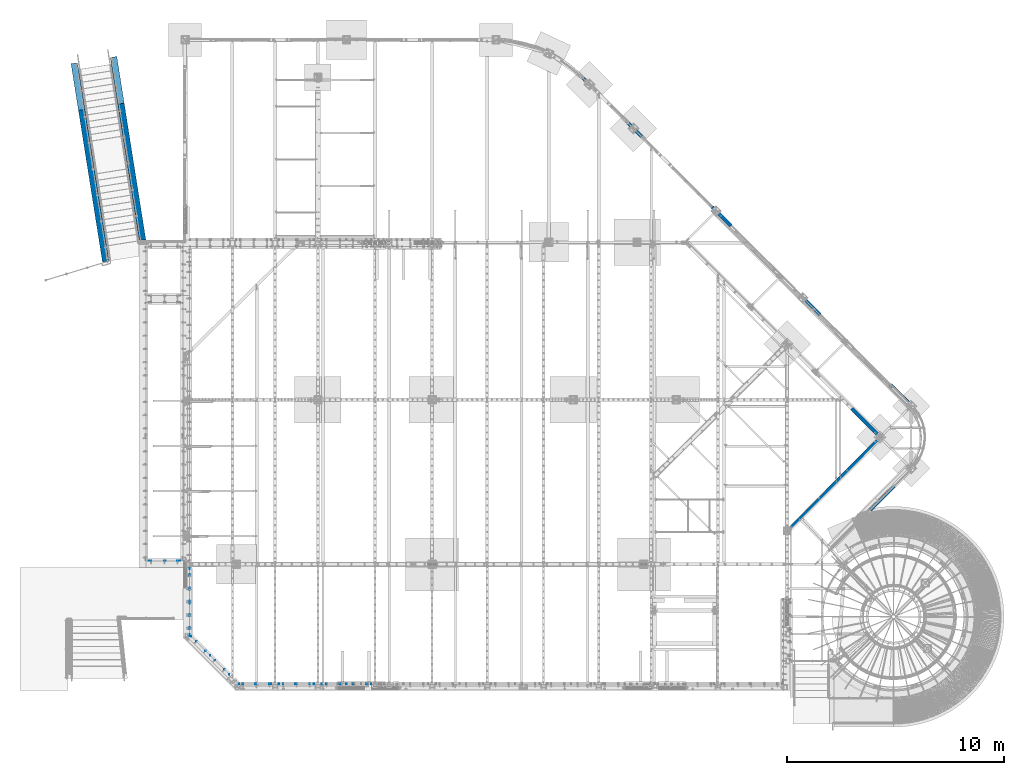
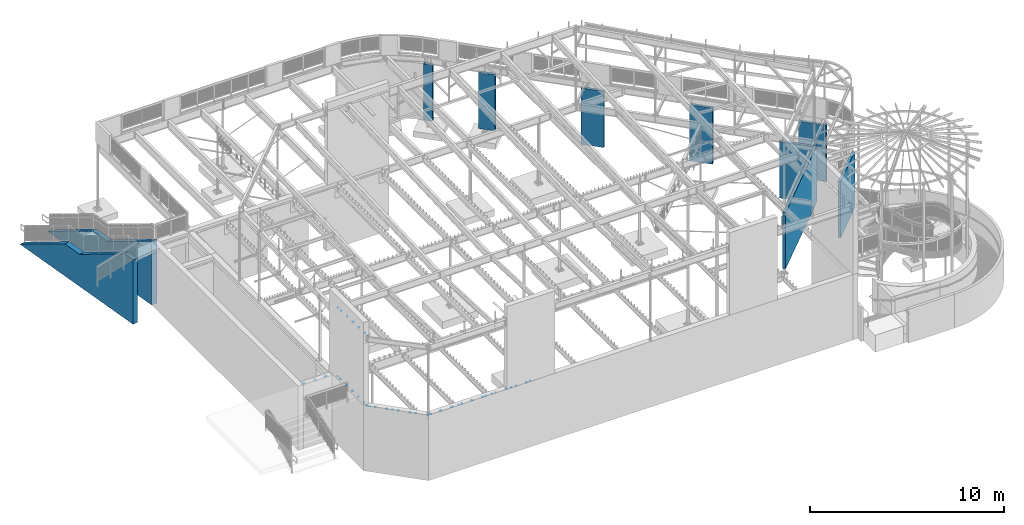
# One storey, part 1 of 975: 14 mechanical fasteners, 10 walls.
"""IFC2X3 building model written with IfcOpenShell, lengths in millimetres."""

import ifcopenshell
import ifcopenshell.guid

model = None  # the IFC model being written
_history = None  # IfcOwnerHistory: only IFC2X3 demands one
_inside = {}  # id of a spatial element -> (the spatial element, [elements in it])
_under = {}  # id of a project, library or spatial element -> (it, [spatial elements below it])
_declared = {}  # id of a project -> (the project, [libraries it declares])
_typed = {}  # id of a type object -> (the type object, [elements of that type])
_made_of = {}  # id of a material, layer set ... -> (it, [elements and type objects made of it])


def new_model(schema):
    """Start an empty IFC model of exactly this schema.

    Asked for "IFC4X3", IfcOpenShell would pick the latest addendum, in which some entities
    have other attributes; the version numbers below select the first issue.
    IFC2X3 requires an IfcOwnerHistory on every rooted entity: one is made here for all.
    """
    global model, _history
    if schema == "IFC4X3":
        model = ifcopenshell.file(schema_version=(4, 3, 0, 0))
    else:
        model = ifcopenshell.file(schema=schema)
    _inside.clear()
    _under.clear()
    _declared.clear()
    _typed.clear()
    _made_of.clear()
    _history = None
    if model.schema == "IFC2X3":
        org = make("IfcOrganization", Name="unknown")
        user = make(
            "IfcPersonAndOrganization",
            ThePerson=make("IfcPerson", FamilyName="unknown"),
            TheOrganization=org,
        )
        app = make(
            "IfcApplication",
            ApplicationDeveloper=org,
            Version="unknown",
            ApplicationFullName="unknown",
            ApplicationIdentifier="unknown",
        )
        _history = make(
            "IfcOwnerHistory",
            OwningUser=user,
            OwningApplication=app,
            ChangeAction="ADDED",
            CreationDate=0,
        )
    return model


def make(cls, **values):
    """One entity of the class cls with the attributes given. An attribute that is None is left unset."""
    return model.create_entity(
        cls, **{name: value for name, value in values.items() if value is not None}
    )


def rooted(cls, **values):
    """An entity with a GlobalId (a new one), such as an element, a storey or a relation."""
    return make(cls, GlobalId=ifcopenshell.guid.new(), OwnerHistory=_history, **values)


def si_unit(unit_type, name, prefix=None):
    """IfcSIUnit, for example si_unit("LENGTHUNIT", "METRE", prefix="MILLI")."""
    return make("IfcSIUnit", UnitType=unit_type, Prefix=prefix, Name=name)


def assignment(units):
    """IfcUnitAssignment: the units of a project."""
    return None if units is None else make("IfcUnitAssignment", Units=units)


def point(xyz):
    """IfcCartesianPoint."""
    return None if xyz is None else make("IfcCartesianPoint", Coordinates=xyz)


def direction(xyz):
    """IfcDirection."""
    return None if xyz is None else make("IfcDirection", DirectionRatios=xyz)


def frame(location, z_axis=None, x_axis=None):
    """IfcAxis2Placement3D, a coordinate frame: its origin and axes. An axis left out is left unset."""
    return make(
        "IfcAxis2Placement3D",
        Location=point(location),
        Axis=direction(z_axis),
        RefDirection=direction(x_axis),
    )


def origin_with_axes():
    """The frame at (0, 0, 0) with the z axis (0, 0, 1) and the x axis (1, 0, 0) written out."""
    return frame((0.0, 0.0, 0.0), z_axis=(0.0, 0.0, 1.0), x_axis=(1.0, 0.0, 0.0))


def place(relative_to, where):
    """IfcLocalPlacement: puts the frame where relative to a parent placement (None: the world)."""
    return make(
        "IfcLocalPlacement", PlacementRelTo=relative_to, RelativePlacement=where
    )


def context(
    kind, dimensions, precision=None, world=None, true_north=None, identifier=None
):
    """IfcGeometricRepresentationContext, for example the 3D "Model" context."""
    return make(
        "IfcGeometricRepresentationContext",
        ContextIdentifier=identifier,
        ContextType=kind,
        CoordinateSpaceDimension=dimensions,
        Precision=precision,
        WorldCoordinateSystem=world,
        TrueNorth=true_north,
    )


def subcontext(parent, identifier, kind, view, scale=None):
    """IfcGeometricRepresentationSubContext, for example "Body" below "Model"."""
    return make(
        "IfcGeometricRepresentationSubContext",
        ContextIdentifier=identifier,
        ContextType=kind,
        ParentContext=parent,
        TargetScale=scale,
        TargetView=view,
    )


def project(units=None, contexts=None):
    """IfcProject with its units and contexts."""
    return rooted(
        "IfcProject",
        Name="project",
        RepresentationContexts=contexts,
        UnitsInContext=assignment(units),
    )


def spatial(cls, under=None, at=None, **own):
    """A site, building, storey or space (cls), placed at a placement, below another one or the project."""
    s = rooted(cls, ObjectPlacement=at, **own)
    if under is not None:
        _under.setdefault(under.id(), (under, []))[1].append(s)
    return s


def faces_of(points, faces, orient=None, outer=None):
    """IfcFace entities. A face is a list of loops; a loop is a list of indices into points, from 0.

    orient and outer hold one flag for each loop. By default every Orientation is true, the
    first loop of a face is its IfcFaceOuterBound and the others are IfcFaceBound.
    """
    made = []
    for i, loops in enumerate(faces):
        bounds = []
        for j, loop in enumerate(loops):
            is_outer = j == 0 if outer is None else outer[i][j]
            bounds.append(
                make(
                    "IfcFaceOuterBound" if is_outer else "IfcFaceBound",
                    Bound=make("IfcPolyLoop", Polygon=[points[k] for k in loop]),
                    Orientation=True if orient is None else orient[i][j],
                )
            )
        made.append(make("IfcFace", Bounds=bounds))
    return made


def faceted_brep(points, faces, orient=None, outer=None, voids=None):
    """IfcFacetedBrep: a solid bounded by flat faces; with voids (closed shells), ...WithVoids."""
    shared = [point(p) for p in points]
    hull = make("IfcClosedShell", CfsFaces=faces_of(shared, faces, orient, outer))
    if voids is None:
        return make("IfcFacetedBrep", Outer=hull)
    return make(
        "IfcFacetedBrepWithVoids",
        Outer=hull,
        Voids=[
            make(cls, CfsFaces=faces_of(shared, fs, o, b)) for cls, fs, o, b in voids
        ],
    )


def shape(context_of_items, identifier, shape_type, items):
    """IfcShapeRepresentation: the items that make up one representation, for example the "Body"."""
    return make(
        "IfcShapeRepresentation",
        ContextOfItems=context_of_items,
        RepresentationIdentifier=identifier,
        RepresentationType=shape_type,
        Items=items,
    )


def source(mapping_origin, context_of_items, identifier, shape_type, items):
    """IfcRepresentationMap: a shape defined once, which mapped items show again and again."""
    return make(
        "IfcRepresentationMap",
        MappingOrigin=mapping_origin,
        MappedRepresentation=shape(context_of_items, identifier, shape_type, items),
    )


def transform(
    local_origin,
    x_axis=None,
    y_axis=None,
    z_axis=None,
    scale=None,
    scale2=None,
    scale3=None,
    uniform=True,
):
    """IfcCartesianTransformationOperator3D, or its non-uniform kind. x_axis, y_axis, z_axis: its Axis1, 2, 3."""
    if uniform:
        return make(
            "IfcCartesianTransformationOperator3D",
            Axis1=direction(x_axis),
            Axis2=direction(y_axis),
            LocalOrigin=point(local_origin),
            Scale=scale,
            Axis3=direction(z_axis),
        )
    return make(
        "IfcCartesianTransformationOperator3DnonUniform",
        Axis1=direction(x_axis),
        Axis2=direction(y_axis),
        LocalOrigin=point(local_origin),
        Scale=scale,
        Axis3=direction(z_axis),
        Scale2=scale2,
        Scale3=scale3,
    )


def mapped(mapping_source, mapping_target):
    """IfcMappedItem: shows the shape of a source again, moved by a transform."""
    return make(
        "IfcMappedItem", MappingSource=mapping_source, MappingTarget=mapping_target
    )


def material(Name=None, Category=None):
    """IfcMaterial."""
    return make("IfcMaterial", Name=Name, Category=Category)


def made_of(thing, what):
    """Note that an element or type object is made of a material, layer set ...; save() writes the relation."""
    if what is not None:
        _made_of.setdefault(what.id(), (what, []))[1].append(thing)
    return thing


def type_object(cls, material=None, **own):
    """A type object (cls), such as IfcWallType, which elements share."""
    return made_of(rooted(cls, **own), material)


def element(
    cls,
    number,
    at=None,
    inside=None,
    cuts=None,
    type_object=None,
    material=None,
    context=None,
    identifier="Body",
    shape_type=None,
    held_by="IfcProductDefinitionShape",
    body=None,
    shapes=None,
    **own,
):
    """One element of the class cls, such as IfcWall. Its Tag is "e" and its number.

    at: its placement. inside: the storey or other place that contains it. cuts: it is an
    opening in that element (IfcRelVoidsElement). A single representation is given by context,
    identifier, shape_type and body (its items); several are given by shapes. held_by: the class
    of the entity that holds the representations. save() writes the other relations.
    """
    e = rooted(cls, Tag="e%d" % number, ObjectPlacement=at, **own)
    if body is not None:
        shapes = [shape(context, identifier, shape_type, body)]
    if shapes is not None:
        e.Representation = make(held_by, Representations=shapes)
    if inside is not None:
        _inside.setdefault(inside.id(), (inside, []))[1].append(e)
    if cuts is not None:
        rooted(
            "IfcRelVoidsElement", RelatingBuildingElement=cuts, RelatedOpeningElement=e
        )
    if type_object is not None:
        _typed.setdefault(type_object.id(), (type_object, []))[1].append(e)
    return made_of(e, material)


def aggregate(whole, parts):
    """IfcRelAggregates: a whole, such as a stair, and the parts it consists of."""
    return rooted("IfcRelAggregates", RelatingObject=whole, RelatedObjects=parts)


def save(model, path):
    """Write the relations noted so far, then the file.

    IfcRelAggregates (storeys below a building ...), IfcRelContainedInSpatialStructure (elements
    in a storey), IfcRelDefinesByType, IfcRelAssociatesMaterial and IfcRelDeclares: one each for
    every whole, place, type object, material and project.
    """
    for whole, parts in _under.values():
        aggregate(whole, parts)
    for where, things in _inside.values():
        rooted(
            "IfcRelContainedInSpatialStructure",
            RelatedElements=things,
            RelatingStructure=where,
        )
    for kind, things in _typed.values():
        rooted("IfcRelDefinesByType", RelatedObjects=things, RelatingType=kind)
    for what, things in _made_of.values():
        rooted("IfcRelAssociatesMaterial", RelatedObjects=things, RelatingMaterial=what)
    for by, libraries in _declared.values():
        rooted("IfcRelDeclares", RelatingContext=by, RelatedDefinitions=libraries)
    model.write(path)


model = new_model("IFC2X3")

# Units and contexts
model_context = context("Model", 3, precision=1e-05, world=origin_with_axes())
body_context = subcontext(model_context, "Body", "Model", "MODEL_VIEW")
ifc_project = project(units=[si_unit("LENGTHUNIT", "METRE", prefix="MILLI"), si_unit("AREAUNIT", "SQUARE_METRE"), si_unit("VOLUMEUNIT", "CUBIC_METRE"), si_unit("MASSUNIT", "GRAM", prefix="KILO"), si_unit("TIMEUNIT", "SECOND"), si_unit("PLANEANGLEUNIT", "RADIAN"), si_unit("SOLIDANGLEUNIT", "STERADIAN"), si_unit("THERMODYNAMICTEMPERATUREUNIT", "DEGREE_CELSIUS"), si_unit("LUMINOUSINTENSITYUNIT", "LUMEN")], contexts=[model_context])

# Site, building, storey
site_placement = place(None, origin_with_axes())
site = spatial("IfcSite", under=ifc_project, at=site_placement, CompositionType="ELEMENT")
building_placement = place(site_placement, origin_with_axes())
building = spatial("IfcBuilding", under=site, at=building_placement, Name="Undefined", CompositionType="ELEMENT")
storey_placement = place(building_placement, origin_with_axes())
storey = spatial("IfcBuildingStorey", under=building, at=storey_placement, Name="Undefined", CompositionType="ELEMENT", Elevation=0.0)

# Walls
ifc_material_1 = material(Name="CONCRETE/5000")
wall_type_1 = type_object("IfcWallType", PredefinedType="NOTDEFINED")
wall_1_placement = place(storey_placement, frame((33644.2109960789, 8295.2659520468, 1765.3), z_axis=(0.0, 0.0, 1.0), x_axis=(0.706328886772485, 0.707883820771984, 0.0)))
element("IfcWall", 1, at=wall_1_placement, inside=storey, type_object=wall_type_1, material=ifc_material_1, Name="STUD WALL", context=body_context, shape_type="Brep", body=[
    faceted_brep([(-1.4915713109076e-10, 76.2000000001099, -1765.3), (-1.4915713109076e-10, 76.2000000001099, 1765.3), (2807.7884741154, 76.2000000021399, 1765.3), (2807.7884741154, 76.2000000021399, -1765.3), (1.52795109897852e-10, -76.2000000001135, 1765.3), (2807.7884741157, -76.1999999980799, 1765.3), (1.52795109897852e-10, -76.2000000001135, -1765.3), (2807.7884741157, -76.1999999980799, -1765.3)], [[[0, 1, 2, 3]], [[1, 4, 5, 2]], [[4, 6, 7, 5]], [[6, 0, 3, 7]], [[5, 7, 3, 2]], [[6, 4, 1, 0]]]),
])
wall_2_placement = place(storey_placement, frame((20450.754909531, 28187.7298580115, 1765.3), z_axis=(0.0, 0.0, 1.0), x_axis=(0.708057881680779, -0.706154399681634, 0.0)))
element("IfcWall", 2, at=wall_2_placement, inside=storey, type_object=wall_type_1, material=ifc_material_1, Name="STUD WALL", context=body_context, shape_type="Brep", body=[
    faceted_brep([(-1.4915713109076e-10, 76.2000000001099, -1765.3), (-1.4915713109076e-10, 76.2000000001099, 1765.3), (487.387012770271, 76.2000000003318, 1765.3), (487.387012770271, 76.2000000003318, -1765.3), (1.52795109897852e-10, -76.2000000001135, 1765.3), (487.38701277034, -76.1999999999098, 1765.3), (1.52795109897852e-10, -76.2000000001135, -1765.3), (487.38701277034, -76.1999999999098, -1765.3)], [[[0, 1, 2, 3]], [[1, 4, 5, 2]], [[4, 6, 7, 5]], [[6, 0, 3, 7]], [[5, 7, 3, 2]], [[6, 4, 1, 0]]]),
])
wall_3_placement = place(storey_placement, frame((22522.045534531, 26121.5986080115, 1765.3), z_axis=(0.0, 0.0, 1.0), x_axis=(0.707962758962496, -0.706249765962588, 0.0)))
element("IfcWall", 3, at=wall_3_placement, inside=storey, type_object=wall_type_1, material=ifc_material_1, Name="STUD WALL", context=body_context, shape_type="Brep", body=[
    faceted_brep([(-1.4915713109076e-10, 76.2000000001099, -1765.3), (-1.4915713109076e-10, 76.2000000001099, 1765.3), (889.113368091343, 76.2000000012413, 1765.3), (889.113368091343, 76.2000000012413, -1765.3), (1.52795109897852e-10, -76.2000000001135, 1765.3), (889.11336809157, -76.1999999986001, 1765.3), (1.52795109897852e-10, -76.2000000001135, -1765.3), (889.11336809157, -76.1999999986001, -1765.3)], [[[0, 1, 2, 3]], [[1, 4, 5, 2]], [[4, 6, 7, 5]], [[6, 0, 3, 7]], [[5, 7, 3, 2]], [[6, 4, 1, 0]]]),
])
for number, where, z_axis, x_axis, name in (
    (4, (26388.004909531, 22264.3704830115, 1765.3), (0.0, 0.0, 1.0), (0.707893750771923, -0.706318934772429, 0.0), "STUD WALL"),
    (5, (30487.525222531, 18173.9782950115, 1765.3), (0.0, 0.0, 1.0), (0.707893750771923, -0.706318934772429, 0.0), "STUD WALL"),
):
    element("IfcWall", number, at=place(storey_placement, frame(where, z_axis=z_axis, x_axis=x_axis)), inside=storey, type_object=wall_type_1, material=ifc_material_1, Name=name, context=body_context, shape_type="Brep", body=[
        faceted_brep([(-1.4915713109076e-10, 76.2000000001099, -1765.3), (-1.4915713109076e-10, 76.2000000001099, 1765.3), (1219.13788418026, 76.2000000007247, 1765.3), (1219.13788418026, 76.2000000007247, -1765.3), (1.52795109897852e-10, -76.2000000001135, 1765.3), (1219.13788418035, -76.1999999992404, 1765.3), (1.52795109897852e-10, -76.2000000001135, -1765.3), (1219.13788418035, -76.1999999992404, -1765.3)], [[[0, 1, 2, 3]], [[1, 4, 5, 2]], [[4, 6, 7, 5]], [[6, 0, 3, 7]], [[5, 7, 3, 2]], [[6, 4, 1, 0]]]),
    ])
wall_4_placement = place(storey_placement, frame((34587.243972531, 14083.5861080115, 1765.3), z_axis=(0.0, 0.0, 1.0), x_axis=(0.707892704937232, -0.706319982937372, 0.0)))
element("IfcWall", 6, at=wall_4_placement, inside=storey, type_object=wall_type_1, material=ifc_material_1, Name="STUD WALL", context=body_context, shape_type="Brep", body=[
    faceted_brep([(-1.4915713109076e-10, 76.2000000001099, -1765.3), (-1.4915713109076e-10, 76.2000000001099, 1765.3), (1473.11090764207, 76.1999999997861, 1765.3), (1473.11090764207, 76.1999999997861, -1765.3), (1.52795109897852e-10, -76.2000000001135, 1765.3), (1473.11090764225, -76.1999999999753, 1765.3), (1.52795109897852e-10, -76.2000000001135, -1765.3), (1473.11090764225, -76.1999999999753, -1765.3)], [[[0, 1, 2, 3]], [[1, 4, 5, 2]], [[4, 6, 7, 5]], [[6, 0, 3, 7]], [[5, 7, 3, 2]], [[6, 4, 1, 0]]]),
])
wall_5_placement = place(storey_placement, frame((32810.434597531, 12986.0282960115, 1765.3), z_axis=(0.0, 0.0, 1.0), x_axis=(0.707913768671437, -0.706298871672186, 0.0)))
element("IfcWall", 7, at=wall_5_placement, inside=storey, type_object=wall_type_1, material=ifc_material_1, Name="STUD WALL", context=body_context, shape_type="Brep", body=[
    faceted_brep([(-1.4915713109076e-10, 76.2000000001099, -1765.3), (-1.4915713109076e-10, 76.2000000001099, 1765.3), (1803.27590172026, 76.2000000041662, 1765.3), (1803.27590172026, 76.2000000041662, -1765.3), (1.52795109897852e-10, -76.2000000001135, 1765.3), (1803.27590172023, -76.1999999956715, 1765.3), (1.52795109897852e-10, -76.2000000001135, -1765.3), (1803.27590172023, -76.1999999956715, -1765.3)], [[[0, 1, 2, 3]], [[1, 4, 5, 2]], [[4, 6, 7, 5]], [[6, 0, 3, 7]], [[5, 7, 3, 2]], [[6, 4, 1, 0]]]),
])
wall_6_placement = place(storey_placement, frame((29796.8194690102, 7304.44517458776, 1765.3), z_axis=(0.0, 0.0, 1.0), x_axis=(0.706298691966854, 0.707913947966779, 0.0)))
element("IfcWall", 8, at=wall_6_placement, inside=storey, type_object=wall_type_1, material=ifc_material_1, Name="STUD WALL", context=body_context, shape_type="Brep", body=[
    faceted_brep([(-1.4915713109076e-10, 76.2000000001099, -1765.3), (-1.4915713109076e-10, 76.2000000001099, 1765.3), (6226.67850368419, 76.2000000011012, 1765.3), (6226.67850368419, 76.2000000011012, -1765.3), (1.52795109897852e-10, -76.2000000001135, 1765.3), (6226.67850368432, -76.1999999991112, 1765.3), (1.52795109897852e-10, -76.2000000001135, -1765.3), (6226.67850368432, -76.1999999991112, -1765.3)], [[[0, 1, 2, 3]], [[1, 4, 5, 2]], [[4, 6, 7, 5]], [[6, 0, 3, 7]], [[5, 7, 3, 2]], [[6, 4, 1, 0]]]),
])
wall_type_2 = type_object("IfcWallType", PredefinedType="NOTDEFINED")
wall_7_placement = place(storey_placement, frame((-2989.53784177653, 28912.1053057628, 2133.6), z_axis=(0.0, 0.0, 1.0), x_axis=(0.156434463962902, -0.98768834076577, 3.20000000030926e-08)))
element("IfcWall", 9, at=wall_7_placement, inside=storey, type_object=wall_type_2, material=ifc_material_1, Name="WALL", context=body_context, shape_type="Brep", body=[
    faceted_brep([(3683.00014933779, -152.400000001002, -114.30007493198), (3683.00014906382, 152.399999998925, -114.300074772158), (25.3999236598211, 152.399999999998, -2133.59999999997), (25.3999242233258, -152.399999999929, -2133.60000000002), (4902.19941206006, -152.400000001345, -114.300450878977), (4902.19941178608, 152.399999998581, -114.300450719155), (8559.79989715778, -152.400000002418, 1904.99975715593), (8559.79989688381, 152.399999997508, 1904.99975731575), (9270.99976788559, -152.400000002619, 1904.99971297351), (9270.99976788562, 152.399999997308, 1904.99971313332), (9270.99976789008, -152.400000002538, -2133.59999999895), (9270.99976789011, 152.399999997389, -2133.5999999989)], [[[0, 1, 2, 3]], [[4, 5, 1, 0]], [[6, 7, 5, 4]], [[8, 9, 7, 6]], [[4, 0, 3, 10, 8, 6]], [[11, 10, 3, 2]], [[11, 2, 1, 5, 7, 9]], [[10, 11, 9, 8]]]),
])
wall_8_placement = place(storey_placement, frame((-1183.25340502172, 29198.1926587145, 2133.6), z_axis=(0.0, 0.0, 1.0), x_axis=(0.156434463962902, -0.98768834076577, 3.20000000030926e-08)))
element("IfcWall", 10, at=wall_8_placement, inside=storey, type_object=wall_type_2, material=ifc_material_1, Name="WALL", context=body_context, shape_type="Brep", body=[
    faceted_brep([(3682.99992570346, -152.399999999383, -114.300197807476), (3682.99992575331, 152.400000000555, -114.300197641807), (25.3999236598211, 152.399999999998, -2133.59999999997), (25.3999242233258, -152.399999999929, -2133.60000000002), (4902.1996158846, -152.3999999992, -114.300338061539), (4902.19961593445, 152.400000000738, -114.300337895869), (8559.80010150287, 30.984447644325, 1904.99986917123), (8559.80010152273, 152.400000000639, 1904.99986923722), (8530.75485787209, -152.399999999298, 1888.9644746511), (8579.03043579677, 152.400000000641, 1904.9998722771), (8530.75472095603, -152.399999998012, -2133.59999999921), (8579.03029833492, 152.400000001933, -2133.59999999916)], [[[0, 1, 2, 3]], [[4, 5, 1, 0]], [[6, 7, 5, 4, 8]], [[9, 7, 6]], [[8, 10, 11, 9, 6]], [[0, 3, 10, 8, 4]], [[11, 10, 3, 2]], [[11, 2, 1, 5, 7, 9]]]),
])

# Mechanical fasteners
ifc_material_2 = material(Name="Undefined")
mechanical_fastener_type = type_object("IfcMechanicalFastenerType", Name="Bolt assembly")
shared_shape_1 = source(origin_with_axes(), body_context, "Body", "Brep", [
    faceted_brep([(8.73124980926514, -50.8000000003153, 0.0), (7.56148414161149, -50.8000000003153, 4.36562490463283), (4.36562490463205, -50.8000000003153, 7.56148414161194), (-9.04850834168241e-13, -50.8000000003153, 8.73124980926514), (-4.36562490463361, -50.8000000003153, 7.56148414161104), (-7.5614841416124, -50.8000000003153, 4.36562490463127), (-8.73124980926514, -50.8000000003153, -1.80970166833648e-12), (-7.56148414161059, -50.8000000003153, -4.36562490463439), (-4.36562490463048, -50.8000000003153, -7.56148414161285), (2.70485886793272e-12, -50.8000000003153, -8.73124980926514), (4.36562490463518, -50.8000000003153, -7.56148414161014), (7.5614841416133, -50.8000000003153, -4.3656249046297), (7.5614841416133, -42.7625000003153, -4.3656249046297), (4.36562490463518, -42.7625000003153, -7.56148414161014), (2.70485886793272e-12, -42.7625000003153, -8.73124980926514), (-4.36562490463048, -42.7625000003153, -7.56148414161285), (-7.56148414161059, -42.7625000003153, -4.36562490463439), (-8.73124980926514, -42.7625000003153, -1.80970166833648e-12), (-7.5614841416124, -42.7625000003153, 4.36562490463127), (-4.36562490463361, -42.7625000003153, 7.56148414161104), (-9.04850834168241e-13, -42.7625000003153, 8.73124980926514), (4.36562490463205, -42.7625000003153, 7.56148414161194), (7.56148414161149, -42.7625000003153, 4.36562490463283), (8.73124980926514, -42.7625000003153, 0.0)], [[[0, 1, 2, 3, 4, 5, 6, 7, 8, 9, 10, 11]], [[12, 13, 14, 15, 16, 17, 18, 19, 20, 21, 22, 23]], [[0, 23, 22, 1]], [[1, 22, 21, 2]], [[2, 21, 20, 3]], [[3, 20, 19, 4]], [[4, 19, 18, 5]], [[5, 18, 17, 6]], [[6, 17, 16, 7]], [[7, 16, 15, 8]], [[8, 15, 14, 9]], [[9, 14, 13, 10]], [[10, 13, 12, 11]], [[11, 12, 23, 0]]]),
])
mechanical_fastener_1_placement = place(storey_placement, frame((2659.19476520712, 2298.22477532727, 3886.2), z_axis=(0.0, 0.0, 1.0), x_axis=(0.707106781186513, -0.707106781186582, 3.1377567211166e-14)))
element("IfcMechanicalFastener", 11, at=mechanical_fastener_1_placement, inside=storey, type_object=mechanical_fastener_type, material=ifc_material_2, Name="Bolt assembly", NominalDiameter=15.875, NominalLength=7.93749809265137, context=body_context, shape_type="MappedRepresentation", body=[
    mapped(shared_shape_1, transform((0.0, 0.0, 0.0))),
    mapped(shared_shape_1, transform((609.599975585942, -8.29459168016911e-10, 0.0))),
    mapped(shared_shape_1, transform((1219.19995117188, -1.66255631484091e-09, 0.0))),
    mapped(shared_shape_1, transform((1828.80004882814, -2.49201548285782e-09, 0.0))),
])
mechanical_fastener_2_placement = place(storey_placement, frame((8629.65, 355.6, 3886.2), z_axis=(0.0, 0.0, 1.0), x_axis=(1.0, 0.0, 0.0)))
element("IfcMechanicalFastener", 12, at=mechanical_fastener_2_placement, inside=storey, type_object=mechanical_fastener_type, material=ifc_material_2, Name="Bolt assembly", NominalDiameter=15.875, NominalLength=7.9375, context=body_context, shape_type="MappedRepresentation", body=[
    mapped(shared_shape_1, transform((0.0, 0.0, 0.0))),
    mapped(shared_shape_1, transform((609.599975585942, -8.29459168016911e-10, 0.0))),
    mapped(shared_shape_1, transform((1219.19995117188, -1.66255631484091e-09, 0.0))),
    mapped(shared_shape_1, transform((1828.80004882814, -2.49201548285782e-09, 0.0))),
])
for number, where, z_axis, x_axis, name in (
    (13, (6635.154687, 355.6, 3886.2), (0.0, 0.0, 1.0), (1.0, 0.0, 0.0), "Bolt assembly"),
    (14, (4779.05960907062, 355.6, 3886.2), (0.0, 0.0, 1.0), (1.0, 0.0, 0.0), "Bolt assembly"),
):
    element("IfcMechanicalFastener", number, at=place(storey_placement, frame(where, z_axis=z_axis, x_axis=x_axis)), inside=storey, type_object=mechanical_fastener_type, material=ifc_material_2, Name=name, NominalDiameter=15.875, NominalLength=7.9375, context=body_context, shape_type="MappedRepresentation", body=[
        mapped(shared_shape_1, transform((0.0, 0.0, 0.0))),
        mapped(shared_shape_1, transform((609.599975585942, -8.29459168016911e-10, 0.0))),
        mapped(shared_shape_1, transform((1219.19995117188, -1.66255631484091e-09, 0.0))),
    ])
shared_shape_2 = source(origin_with_axes(), body_context, "Body", "Brep", [
    faceted_brep([(3.96875, -7.93749133016791, 0.0), (3.43703832126942, -7.93749133016791, 1.98437500000012), (1.98437499999976, -7.93749133016791, 3.43703832126963), (-4.11295842697628e-13, -7.93749133016791, 3.96875), (-1.98437500000047, -7.93749133016791, 3.43703832126922), (-3.43703832126983, -7.93749133016791, 1.98437499999941), (-3.96875, -7.93749133016791, -8.22591685395256e-13), (-3.43703832126901, -7.93749133016791, -1.98437500000083), (-1.98437499999905, -7.93749133016791, -3.43703832127004), (1.2294813304639e-12, -7.93749133016791, -3.96875), (1.98437500000118, -7.93749133016791, -3.43703832126881), (3.43703832127024, -7.93749133016791, -1.9843749999987), (3.43703832127024, 0.0999999999999996, -1.9843749999987), (1.98437500000118, 0.0999999999999996, -3.43703832126881), (1.2294813304639e-12, 0.0999999999999996, -3.96875), (-1.98437499999905, 0.0999999999999996, -3.43703832127004), (-3.43703832126901, 0.0999999999999996, -1.98437500000083), (-3.96875, 0.0999999999999996, -8.22591685395256e-13), (-3.43703832126983, 0.0999999999999996, 1.98437499999941), (-1.98437500000047, 0.0999999999999996, 3.43703832126922), (-4.11295842697628e-13, 0.0999999999999996, 3.96875), (1.98437499999976, 0.0999999999999996, 3.43703832126963), (3.43703832126942, 0.0999999999999996, 1.98437500000012), (3.96875, 0.0999999999999996, 0.0)], [[[0, 1, 2, 3, 4, 5, 6, 7, 8, 9, 10, 11]], [[12, 13, 14, 15, 16, 17, 18, 19, 20, 21, 22, 23]], [[0, 23, 22, 1]], [[1, 22, 21, 2]], [[2, 21, 20, 3]], [[3, 20, 19, 4]], [[4, 19, 18, 5]], [[5, 18, 17, 6]], [[6, 17, 16, 7]], [[7, 16, 15, 8]], [[8, 15, 14, 9]], [[9, 14, 13, 10]], [[10, 13, 12, 11]], [[11, 12, 23, 0]]]),
])
mechanical_fastener_3_placement = place(storey_placement, frame((6348.94172920507, 312.7375, 3886.2), z_axis=(0.0, 0.0, 1.0), x_axis=(1.0, 0.0, 0.0)))
element("IfcMechanicalFastener", 15, at=mechanical_fastener_3_placement, inside=storey, type_object=mechanical_fastener_type, material=ifc_material_2, Name="Bolt assembly", NominalDiameter=6.34999990463257, NominalLength=7.9375, context=body_context, shape_type="MappedRepresentation", body=[
    mapped(shared_shape_2, transform((88.8999786376953, 0.0, 0.0))),
    mapped(shared_shape_2, transform((844.549987792969, 0.0, 0.0))),
    mapped(shared_shape_2, transform((1702.85827636719, 0.0, 0.0))),
])
mechanical_fastener_4_placement = place(storey_placement, frame((4606.17748893617, 312.7375, 3886.2), z_axis=(0.0, 0.0, 1.0), x_axis=(1.0, 0.0, 0.0)))
element("IfcMechanicalFastener", 16, at=mechanical_fastener_4_placement, inside=storey, type_object=mechanical_fastener_type, material=ifc_material_2, Name="Bolt assembly", NominalDiameter=6.34999990463257, NominalLength=7.9375, context=body_context, shape_type="MappedRepresentation", body=[
    mapped(shared_shape_2, transform((0.0, 0.0, 0.0))),
    mapped(shared_shape_2, transform((731.837524414062, 0.0, 0.0))),
    mapped(shared_shape_2, transform((1476.06420898438, 0.0, 0.0))),
])
mechanical_fastener_5_placement = place(storey_placement, frame((444.499990624662, 5981.7000000504, 3835.4), z_axis=(0.0, 0.0, -1.0), x_axis=(1.0, 0.0, 0.0)))
element("IfcMechanicalFastener", 17, at=mechanical_fastener_5_placement, inside=storey, type_object=mechanical_fastener_type, material=ifc_material_2, Name="Bolt assembly", NominalDiameter=6.34999990463257, NominalLength=7.9375, context=body_context, shape_type="MappedRepresentation", body=[
    mapped(shared_shape_2, transform((0.0, 0.0, 0.0))),
    mapped(shared_shape_2, transform((766.762512207031, 0.0, 0.0))),
    mapped(shared_shape_2, transform((1431.92504882812, 0.0, 0.0))),
])
shared_shape_3 = source(origin_with_axes(), body_context, "Body", "Brep", [
    faceted_brep([(3.96875, 4.56485338418133e-09, 0.0), (3.43703832126942, 4.56485338418133e-09, 1.98437500000012), (1.98437499999976, 4.56485338418133e-09, 3.43703832126963), (-4.11295842697628e-13, 4.56485338418133e-09, 3.96875), (-1.98437500000047, 4.56485338418133e-09, 3.43703832126922), (-3.43703832126983, 4.56485338418133e-09, 1.98437499999941), (-3.96875, 4.56485338418133e-09, -8.22591685395256e-13), (-3.43703832126901, 4.56485338418133e-09, -1.98437500000083), (-1.98437499999905, 4.56485338418133e-09, -3.43703832127004), (1.2294813304639e-12, 4.56485338418133e-09, -3.96875), (1.98437500000118, 4.56485338418133e-09, -3.43703832126881), (3.43703832127024, 4.56485338418133e-09, -1.9843749999987), (3.43703832127024, 8.03750000478438, -1.9843749999987), (1.98437500000118, 8.03750000478438, -3.43703832126881), (1.2294813304639e-12, 8.03750000478438, -3.96875), (-1.98437499999905, 8.03750000478438, -3.43703832127004), (-3.43703832126901, 8.03750000478438, -1.98437500000083), (-3.96875, 8.03750000478438, -8.22591685395256e-13), (-3.43703832126983, 8.03750000478438, 1.98437499999941), (-1.98437500000047, 8.03750000478438, 3.43703832126922), (-4.11295842697628e-13, 8.03750000478438, 3.96875), (1.98437499999976, 8.03750000478438, 3.43703832126963), (3.43703832126942, 8.03750000478438, 1.98437500000012), (3.96875, 8.03750000478438, 0.0)], [[[0, 1, 2, 3, 4, 5, 6, 7, 8, 9, 10, 11]], [[12, 13, 14, 15, 16, 17, 18, 19, 20, 21, 22, 23]], [[0, 23, 22, 1]], [[1, 22, 21, 2]], [[2, 21, 20, 3]], [[3, 20, 19, 4]], [[4, 19, 18, 5]], [[5, 18, 17, 6]], [[6, 17, 16, 7]], [[7, 16, 15, 8]], [[8, 15, 14, 9]], [[9, 14, 13, 10]], [[10, 13, 12, 11]], [[11, 12, 23, 0]]]),
])
mechanical_fastener_6_placement = place(storey_placement, frame((2328.86231144478, 2503.55897865819, 8321.73114838428), z_axis=(6.64140316075645e-09, 0.0392496009814658, 0.999229437528136), x_axis=(8.29999999712945e-08, 0.999229437528133, -0.0392496009814648)))
element("IfcMechanicalFastener", 18, at=mechanical_fastener_6_placement, inside=storey, type_object=mechanical_fastener_type, material=ifc_material_2, Name="Bolt assembly", NominalDiameter=6.34999990463257, NominalLength=7.9375, context=body_context, shape_type="MappedRepresentation", body=[
    mapped(shared_shape_3, transform((0.0, 0.0, 0.0))),
    mapped(shared_shape_3, transform((1501.77502441466, 1.92812876775861e-10, 7.07586877979338e-10))),
    mapped(shared_shape_3, transform((3105.14990234498, 3.98813426727429e-10, 1.46610545925796e-09))),
])
shared_shape_4 = source(origin_with_axes(), body_context, "Body", "Brep", [
    faceted_brep([(3.96875, -50.8000000000478, 0.0), (3.43703832126942, -50.8000000000478, 1.98437500000012), (1.98437499999976, -50.8000000000478, 3.43703832126963), (-4.11295842697628e-13, -50.8000000000478, 3.96875), (-1.98437500000047, -50.8000000000478, 3.43703832126922), (-3.43703832126983, -50.8000000000478, 1.98437499999941), (-3.96875, -50.8000000000478, -8.22591685395256e-13), (-3.43703832126901, -50.8000000000478, -1.98437500000083), (-1.98437499999905, -50.8000000000478, -3.43703832127004), (1.2294813304639e-12, -50.8000000000478, -3.96875), (1.98437500000118, -50.8000000000478, -3.43703832126881), (3.43703832127024, -50.8000000000478, -1.9843749999987), (3.43703832127024, -42.7625000000438, -1.9843749999987), (1.98437500000118, -42.7625000000438, -3.43703832126881), (1.2294813304639e-12, -42.7625000000438, -3.96875), (-1.98437499999905, -42.7625000000438, -3.43703832127004), (-3.43703832126901, -42.7625000000438, -1.98437500000083), (-3.96875, -42.7625000000438, -8.22591685395256e-13), (-3.43703832126983, -42.7625000000438, 1.98437499999941), (-1.98437500000047, -42.7625000000438, 3.43703832126922), (-4.11295842697628e-13, -42.7625000000438, 3.96875), (1.98437499999976, -42.7625000000438, 3.43703832126963), (3.43703832126942, -42.7625000000438, 1.98437500000012), (3.96875, -42.7625000000438, 0.0)], [[[0, 1, 2, 3, 4, 5, 6, 7, 8, 9, 10, 11]], [[12, 13, 14, 15, 16, 17, 18, 19, 20, 21, 22, 23]], [[0, 23, 22, 1]], [[1, 22, 21, 2]], [[2, 21, 20, 3]], [[3, 20, 19, 4]], [[4, 19, 18, 5]], [[5, 18, 17, 6]], [[6, 17, 16, 7]], [[7, 16, 15, 8]], [[8, 15, 14, 9]], [[9, 14, 13, 10]], [[10, 13, 12, 11]], [[11, 12, 23, 0]]]),
])
mechanical_fastener_7_placement = place(storey_placement, frame((2434.58661380561, 2522.83292704638, 3886.2), z_axis=(0.0, 0.0, 1.0), x_axis=(0.707106781186513, -0.707106781186582, 3.1377567211166e-14)))
element("IfcMechanicalFastener", 19, at=mechanical_fastener_7_placement, inside=storey, type_object=mechanical_fastener_type, material=ifc_material_2, Name="Bolt assembly", NominalDiameter=6.34999990463257, NominalLength=7.93749809265137, context=body_context, shape_type="MappedRepresentation", body=[
    mapped(shared_shape_4, transform((0.0, 0.0, 0.0))),
    mapped(shared_shape_4, transform((1231.90002441369, 0.0, 0.0))),
    mapped(shared_shape_4, transform((2463.80004882737, -4.54747350886464e-13, 0.0))),
])
mechanical_fastener_8_placement = place(storey_placement, frame((8318.5, 355.599999999998, 3886.2), z_axis=(0.0, 0.0, 1.0), x_axis=(1.0, 0.0, 0.0)))
element("IfcMechanicalFastener", 20, at=mechanical_fastener_8_placement, inside=storey, type_object=mechanical_fastener_type, material=ifc_material_2, Name="Bolt assembly", NominalDiameter=6.34999990463257, NominalLength=7.93749904632568, context=body_context, shape_type="MappedRepresentation", body=[
    mapped(shared_shape_4, transform((88.8999786376953, 0.0, 0.0))),
    mapped(shared_shape_4, transform((1225.55004882812, 0.0, 0.0))),
    mapped(shared_shape_4, transform((2362.2001953125, 0.0, 0.0))),
])
shared_shape_5 = source(origin_with_axes(), body_context, "Body", "Brep", [
    faceted_brep([(3.96875, 42.8625096405521, 0.0), (3.43703832126942, 42.8625096405521, 1.98437500000012), (1.98437499999976, 42.8625096405521, 3.43703832126963), (-4.11295842697628e-13, 42.8625096405521, 3.96875), (-1.98437500000047, 42.8625096405521, 3.43703832126922), (-3.43703832126983, 42.8625096405521, 1.98437499999941), (-3.96875, 42.8625096405521, -8.22591685395256e-13), (-3.43703832126901, 42.8625096405521, -1.98437500000083), (-1.98437499999905, 42.8625096405521, -3.43703832127004), (1.2294813304639e-12, 42.8625096405521, -3.96875), (1.98437500000118, 42.8625096405521, -3.43703832126881), (3.43703832127024, 42.8625096405521, -1.9843749999987), (3.43703832127024, 50.9000096405523, -1.9843749999987), (1.98437500000118, 50.9000096405523, -3.43703832126881), (1.2294813304639e-12, 50.9000096405523, -3.96875), (-1.98437499999905, 50.9000096405523, -3.43703832127004), (-3.43703832126901, 50.9000096405523, -1.98437500000083), (-3.96875, 50.9000096405523, -8.22591685395256e-13), (-3.43703832126983, 50.9000096405523, 1.98437499999941), (-1.98437500000047, 50.9000096405523, 3.43703832126922), (-4.11295842697628e-13, 50.9000096405523, 3.96875), (1.98437499999976, 50.9000096405523, 3.43703832126963), (3.43703832126942, 50.9000096405523, 1.98437500000012), (3.96875, 50.9000096405523, 0.0)], [[[0, 1, 2, 3, 4, 5, 6, 7, 8, 9, 10, 11]], [[12, 13, 14, 15, 16, 17, 18, 19, 20, 21, 22, 23]], [[0, 23, 22, 1]], [[1, 22, 21, 2]], [[2, 21, 20, 3]], [[3, 20, 19, 4]], [[4, 19, 18, 5]], [[5, 18, 17, 6]], [[6, 17, 16, 7]], [[7, 16, 15, 8]], [[8, 15, 14, 9]], [[9, 14, 13, 10]], [[10, 13, 12, 11]], [[11, 12, 23, 0]]]),
])
mechanical_fastener_9_placement = place(storey_placement, frame((2371.72481801533, 2590.05266968717, 3886.2), z_axis=(0.0, 0.0, 1.0), x_axis=(0.0, 1.0, 0.0)))
element("IfcMechanicalFastener", 21, at=mechanical_fastener_9_placement, inside=storey, type_object=mechanical_fastener_type, material=ifc_material_2, Name="Bolt assembly", NominalDiameter=6.34999990463257, NominalLength=7.93749904632568, context=body_context, shape_type="MappedRepresentation", body=[
    mapped(shared_shape_5, transform((0.0, 0.0, 0.0))),
    mapped(shared_shape_5, transform((1487.48754882813, 0.0, 0.0))),
    mapped(shared_shape_5, transform((3051.17504882814, -4.54747350886464e-13, 0.0))),
])
shared_shape_6 = source(origin_with_axes(), body_context, "Body", "Brep", [
    faceted_brep([(8.73124980926514, 42.8625050442192, 0.0), (7.56148414161149, 42.8625050442192, 4.36562490463283), (4.36562490463205, 42.8625050442192, 7.56148414161194), (-9.04850834168241e-13, 42.8625050442192, 8.73124980926514), (-4.36562490463361, 42.8625050442192, 7.56148414161104), (-7.5614841416124, 42.8625050442192, 4.36562490463127), (-8.73124980926514, 42.8625050442192, -1.80970166833648e-12), (-7.56148414161059, 42.8625050442192, -4.36562490463439), (-4.36562490463048, 42.8625050442192, -7.56148414161285), (2.70485886793272e-12, 42.8625050442192, -8.73124980926514), (4.36562490463518, 42.8625050442192, -7.56148414161014), (7.5614841416133, 42.8625050442192, -4.3656249046297), (7.5614841416133, 50.9000050442192, -4.3656249046297), (4.36562490463518, 50.9000050442192, -7.56148414161014), (2.70485886793272e-12, 50.9000050442192, -8.73124980926514), (-4.36562490463048, 50.9000050442192, -7.56148414161285), (-7.56148414161059, 50.9000050442192, -4.36562490463439), (-8.73124980926514, 50.9000050442192, -1.80970166833648e-12), (-7.5614841416124, 50.9000050442192, 4.36562490463127), (-4.36562490463361, 50.9000050442192, 7.56148414161104), (-9.04850834168241e-13, 50.9000050442192, 8.73124980926514), (4.36562490463205, 50.9000050442192, 7.56148414161194), (7.56148414161149, 50.9000050442192, 4.36562490463283), (8.73124980926514, 50.9000050442192, 0.0)], [[[0, 1, 2, 3, 4, 5, 6, 7, 8, 9, 10, 11]], [[12, 13, 14, 15, 16, 17, 18, 19, 20, 21, 22, 23]], [[0, 23, 22, 1]], [[1, 22, 21, 2]], [[2, 21, 20, 3]], [[3, 20, 19, 4]], [[4, 19, 18, 5]], [[5, 18, 17, 6]], [[6, 17, 16, 7]], [[7, 16, 15, 8]], [[8, 15, 14, 9]], [[9, 14, 13, 10]], [[10, 13, 12, 11]], [[11, 12, 23, 0]]]),
])
mechanical_fastener_10_placement = place(storey_placement, frame((2371.72483688553, 2909.88750000001, 3886.2), z_axis=(0.0, 0.0, 1.0), x_axis=(0.0, 1.0, 0.0)))
element("IfcMechanicalFastener", 22, at=mechanical_fastener_10_placement, inside=storey, type_object=mechanical_fastener_type, material=ifc_material_2, Name="Bolt assembly", NominalDiameter=15.875, NominalLength=7.9375, context=body_context, shape_type="MappedRepresentation", body=[
    mapped(shared_shape_6, transform((0.0, 0.0, 0.0))),
    mapped(shared_shape_6, transform((609.599975585942, -8.29459168016911e-10, 0.0))),
    mapped(shared_shape_6, transform((1219.19995117188, -1.66255631484091e-09, 0.0))),
    mapped(shared_shape_6, transform((1828.80004882814, -2.49201548285782e-09, 0.0))),
    mapped(shared_shape_6, transform((2438.39990234377, -3.32511262968183e-09, 0.0))),
])
shared_shape_7 = source(origin_with_axes(), body_context, "Body", "Brep", [
    faceted_brep([(8.73124980926514, -7.93750002969256, 0.0), (7.56148414161149, -7.93750002969256, 4.36562490463283), (4.36562490463205, -7.93750002969256, 7.56148414161194), (-9.04850834168241e-13, -7.93750002969256, 8.73124980926514), (-4.36562490463361, -7.93750002969256, 7.56148414161104), (-7.5614841416124, -7.93750002969256, 4.36562490463127), (-8.73124980926514, -7.93750002969256, -1.80970166833648e-12), (-7.56148414161059, -7.93750002969256, -4.36562490463439), (-4.36562490463048, -7.93750002969256, -7.56148414161285), (2.70485886793272e-12, -7.93750002969256, -8.73124980926514), (4.36562490463518, -7.93750002969256, -7.56148414161014), (7.5614841416133, -7.93750002969256, -4.3656249046297), (7.5614841416133, 0.100000000001371, -4.3656249046297), (4.36562490463518, 0.100000000001371, -7.56148414161014), (2.70485886793272e-12, 0.100000000001371, -8.73124980926514), (-4.36562490463048, 0.100000000001371, -7.56148414161285), (-7.56148414161059, 0.100000000001371, -4.36562490463439), (-8.73124980926514, 0.100000000001371, -1.80970166833648e-12), (-7.5614841416124, 0.100000000001371, 4.36562490463127), (-4.36562490463361, 0.100000000001371, 7.56148414161104), (-9.04850834168241e-13, 0.100000000001371, 8.73124980926514), (4.36562490463205, 0.100000000001371, 7.56148414161194), (7.56148414161149, 0.100000000001371, 4.36562490463283), (8.73124980926514, 0.100000000001371, 0.0)], [[[0, 1, 2, 3, 4, 5, 6, 7, 8, 9, 10, 11]], [[12, 13, 14, 15, 16, 17, 18, 19, 20, 21, 22, 23]], [[0, 23, 22, 1]], [[1, 22, 21, 2]], [[2, 21, 20, 3]], [[3, 20, 19, 4]], [[4, 19, 18, 5]], [[5, 18, 17, 6]], [[6, 17, 16, 7]], [[7, 16, 15, 8]], [[8, 15, 14, 9]], [[9, 14, 13, 10]], [[10, 13, 12, 11]], [[11, 12, 23, 0]]]),
])
mechanical_fastener_11_placement = place(storey_placement, frame((550.862524737204, 5981.6999997141, 3835.4), z_axis=(0.0, 0.0, -1.0), x_axis=(1.0, 0.0, 0.0)))
element("IfcMechanicalFastener", 23, at=mechanical_fastener_11_placement, inside=storey, type_object=mechanical_fastener_type, material=ifc_material_2, Name="Bolt assembly", NominalDiameter=15.875, NominalLength=7.9375, context=body_context, shape_type="MappedRepresentation", body=[
    mapped(shared_shape_7, transform((0.0, 0.0, 0.0))),
    mapped(shared_shape_7, transform((609.599975585942, -8.29459168016911e-10, 0.0))),
    mapped(shared_shape_7, transform((1219.19995117188, -1.66255631484091e-09, 0.0))),
])
shared_shape_8 = source(origin_with_axes(), body_context, "Body", "Brep", [
    faceted_brep([(10.3187503814697, -1.88977047343997e-07, 0.0), (8.93629996566297, -1.88977047343997e-07, 5.15937519073517), (5.15937519073425, -1.88977047343997e-07, 8.93629996566351), (-1.06936923054691e-12, -1.88977047343997e-07, 10.3187503814697), (-5.1593751907361, -1.88977047343997e-07, 8.93629996566244), (-8.93629996566404, -1.88977047343997e-07, 5.15937519073332), (-10.3187503814697, -1.88977047343997e-07, -2.13873846109383e-12), (-8.93629996566191, -1.88977047343997e-07, -5.15937519073702), (-5.1593751907324, -1.88977047343997e-07, -8.93629996566457), (3.19665157738187e-12, -1.88977047343997e-07, -10.3187503814697), (5.15937519073794, -1.88977047343997e-07, -8.93629996566137), (8.93629996566511, -1.88977047343997e-07, -5.15937519073147), (8.93629996566511, 8.03749981123079, -5.15937519073147), (5.15937519073794, 8.03749981123079, -8.93629996566137), (3.19665157738187e-12, 8.03749981123079, -10.3187503814697), (-5.1593751907324, 8.03749981123079, -8.93629996566457), (-8.93629996566191, 8.03749981123079, -5.15937519073702), (-10.3187503814697, 8.03749981123079, -2.13873846109383e-12), (-8.93629996566404, 8.03749981123079, 5.15937519073332), (-5.1593751907361, 8.03749981123079, 8.93629996566244), (-1.06936923054691e-12, 8.03749981123079, 10.3187503814697), (5.15937519073425, 8.03749981123079, 8.93629996566351), (8.93629996566297, 8.03749981123079, 5.15937519073517), (10.3187503814697, 8.03749981123079, 0.0)], [[[0, 1, 2, 3, 4, 5, 6, 7, 8, 9, 10, 11]], [[12, 13, 14, 15, 16, 17, 18, 19, 20, 21, 22, 23]], [[0, 23, 22, 1]], [[1, 22, 21, 2]], [[2, 21, 20, 3]], [[3, 20, 19, 4]], [[4, 19, 18, 5]], [[5, 18, 17, 6]], [[6, 17, 16, 7]], [[7, 16, 15, 8]], [[8, 15, 14, 9]], [[9, 14, 13, 10]], [[10, 13, 12, 11]], [[11, 12, 23, 0]]]),
])
mechanical_fastener_12_placement = place(storey_placement, frame((2320.92483908397, 2836.30586493642, 8308.66089421238), z_axis=(-1.05597723631945e-08, -0.0392496009814658, -0.999229437528136), x_axis=(8.29999999712945e-08, 0.999229437528133, -0.0392496009814648)))
element("IfcMechanicalFastener", 24, at=mechanical_fastener_12_placement, inside=storey, type_object=mechanical_fastener_type, material=ifc_material_2, Name="Bolt assembly", NominalDiameter=15.875, NominalLength=7.9375, context=body_context, shape_type="MappedRepresentation", body=[
    mapped(shared_shape_8, transform((0.0, 0.0, 0.0))),
    mapped(shared_shape_8, transform((609.599975585942, -8.29459168016911e-10, 0.0))),
    mapped(shared_shape_8, transform((1219.19995117188, -1.66255631484091e-09, 0.0))),
    mapped(shared_shape_8, transform((1828.80004882814, -2.49201548285782e-09, 0.0))),
    mapped(shared_shape_8, transform((2438.39990234377, -3.32511262968183e-09, 0.0))),
])

save(model, "model.ifc")
